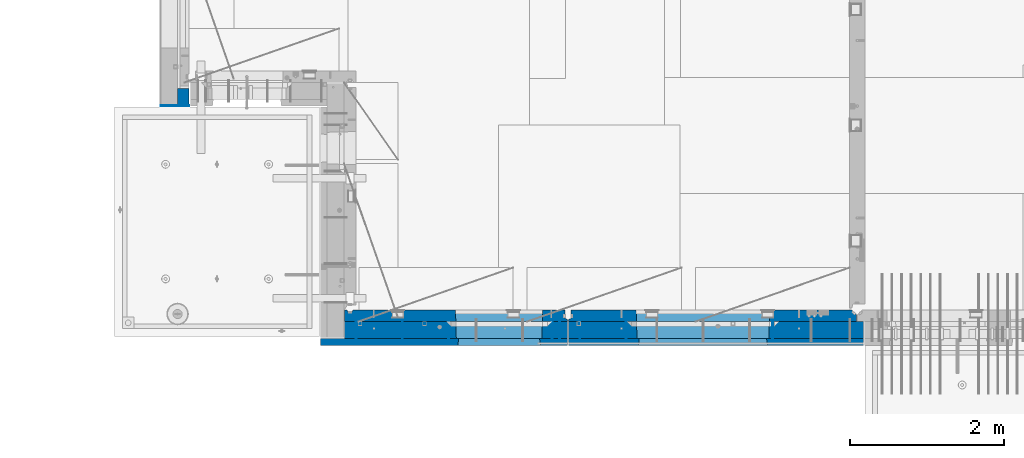
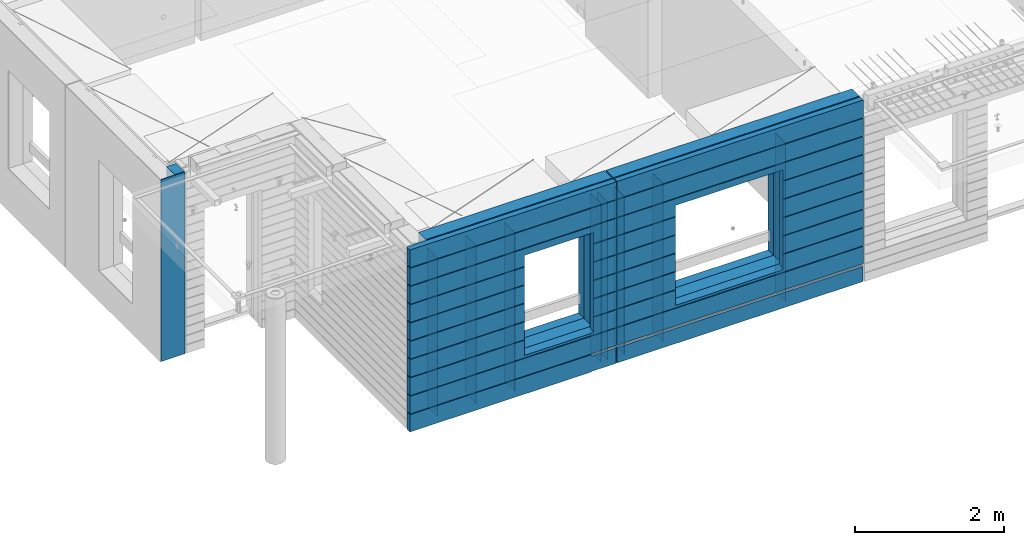
# One storey, part 227 of 350: 16 walls, 3 elements without a shape of their own.
"""IFC2X3 building model written with IfcOpenShell, lengths in millimetres."""

from ifc_helpers import new_model, si_unit, frame, origin_with_axes, place, context, subcontext, project, spatial, faceted_brep, material, type_object, element, aggregate, save


model = new_model("IFC2X3")

# Units and contexts
model_context = context("Model", 3, precision=1e-05, world=origin_with_axes())
body_context = subcontext(model_context, "Body", "Model", "MODEL_VIEW")
ifc_project = project(units=[si_unit("LENGTHUNIT", "METRE", prefix="MILLI"), si_unit("AREAUNIT", "SQUARE_METRE"), si_unit("VOLUMEUNIT", "CUBIC_METRE"), si_unit("MASSUNIT", "GRAM", prefix="KILO"), si_unit("TIMEUNIT", "SECOND"), si_unit("PLANEANGLEUNIT", "RADIAN"), si_unit("SOLIDANGLEUNIT", "STERADIAN"), si_unit("THERMODYNAMICTEMPERATUREUNIT", "DEGREE_CELSIUS"), si_unit("LUMINOUSINTENSITYUNIT", "LUMEN")], contexts=[model_context])

# Site, building, storey
site_placement = place(None, origin_with_axes())
site = spatial("IfcSite", under=ifc_project, at=site_placement, CompositionType="ELEMENT")
building_placement = place(site_placement, origin_with_axes())
building = spatial("IfcBuilding", under=site, at=building_placement, CompositionType="ELEMENT")
storey_placement = place(building_placement, origin_with_axes())
storey = spatial("IfcBuildingStorey", under=building, at=storey_placement, Name="2", CompositionType="ELEMENT", Elevation=0.0)

# Assembly, walls
assembly_1_placement = place(storey_placement, origin_with_axes())
assembly_1 = element("IfcElementAssembly", 1, at=assembly_1_placement, inside=storey, AssemblyPlace="NOTDEFINED", PredefinedType="REINFORCEMENT_UNIT")
ifc_material_1 = material(Name="Undefined")
wall_type_1 = type_object("IfcWallType", PredefinedType="NOTDEFINED")
wall_1_placement = place(assembly_1_placement, frame((10165.0, 7880.0, 86115.0), z_axis=(0.0, 0.0, 1.0), x_axis=(0.0, -1.0, 0.0)))
wall_1 = element("IfcWall", 2, at=wall_1_placement, type_object=wall_type_1, material=ifc_material_1, Name="(PD)", context=body_context, shape_type="Brep", body=[
    faceted_brep([(0.0, 5.0, -1300.0), (0.0, 5.0, 1300.0), (280.0, 5.0, 1300.0), (280.0, 5.0, -1300.0), (0.0, -5.0, 1300.0), (280.0, -5.0, 1300.0), (0.0, -5.0, -1300.0), (280.0, -5.0, -1300.0)], [[[0, 1, 2, 3]], [[1, 4, 5, 2]], [[4, 6, 7, 5]], [[6, 0, 3, 7]], [[5, 7, 3, 2]], [[6, 4, 1, 0]]]),
])
wall_2_placement = place(assembly_1_placement, frame((10765.0, 7880.0, 86115.0), z_axis=(0.0, 0.0, 1.0), x_axis=(0.0, -1.0, 0.0)))
wall_2 = element("IfcWall", 3, at=wall_2_placement, type_object=wall_type_1, material=ifc_material_1, Name="(PD)", context=body_context, shape_type="Brep", body=[
    faceted_brep([(0.0, 5.0, -1300.0), (0.0, 5.0, 1300.0), (280.0, 5.0, 1300.0), (280.0, 5.0, -1300.0), (0.0, -5.0, 1300.0), (280.0, -5.0, 1300.0), (0.0, -5.0, -1300.0), (280.0, -5.0, -1300.0)], [[[0, 1, 2, 3]], [[1, 4, 5, 2]], [[4, 6, 7, 5]], [[6, 0, 3, 7]], [[5, 7, 3, 2]], [[6, 4, 1, 0]]]),
])
wall_3_placement = place(assembly_1_placement, frame((12705.0, 7880.0, 86115.0), z_axis=(0.0, 0.0, 1.0), x_axis=(0.0, -1.0, 0.0)))
wall_3 = element("IfcWall", 4, at=wall_3_placement, type_object=wall_type_1, material=ifc_material_1, Name="(PD)", context=body_context, shape_type="Brep", body=[
    faceted_brep([(0.0, 5.0, -1300.0), (0.0, 5.0, 1300.0), (280.0, 5.0, 1300.0), (280.0, 5.0, -1300.0), (0.0, -5.0, 1300.0), (280.0, -5.0, 1300.0), (0.0, -5.0, -1300.0), (280.0, -5.0, -1300.0)], [[[0, 1, 2, 3]], [[1, 4, 5, 2]], [[4, 6, 7, 5]], [[6, 0, 3, 7]], [[5, 7, 3, 2]], [[6, 4, 1, 0]]]),
])
wall_4_placement = place(assembly_1_placement, frame((12805.0, 7880.0, 86115.0), z_axis=(0.0, 0.0, 1.0), x_axis=(0.0, -1.0, 0.0)))
wall_4 = element("IfcWall", 5, at=wall_4_placement, type_object=wall_type_1, material=ifc_material_1, Name="(PD)", context=body_context, shape_type="Brep", body=[
    faceted_brep([(0.0, 5.0, -1300.0), (0.0, 5.0, 1300.0), (280.0, 5.0, 1300.0), (280.0, 5.0, -1300.0), (0.0, -5.0, 1300.0), (280.0, -5.0, 1300.0), (0.0, -5.0, -1300.0), (280.0, -5.0, -1300.0)], [[[0, 1, 2, 3]], [[1, 4, 5, 2]], [[4, 6, 7, 5]], [[6, 0, 3, 7]], [[5, 7, 3, 2]], [[6, 4, 1, 0]]]),
])
wall_5_placement = place(assembly_1_placement, frame((11365.0, 7880.0, 86115.0), z_axis=(0.0, 0.0, 1.0), x_axis=(0.0, -1.0, 0.0)))
wall_5 = element("IfcWall", 6, at=wall_5_placement, type_object=wall_type_1, material=ifc_material_1, Name="(PD)", context=body_context, shape_type="Brep", body=[
    faceted_brep([(0.0, 5.0, -1300.0), (0.0, 5.0, 1300.0), (280.0, 5.0, 1300.0), (280.0, 5.0, -1300.0), (0.0, -5.0, 1300.0), (280.0, -5.0, 1300.0), (0.0, -5.0, -1300.0), (280.0, -5.0, -1300.0)], [[[0, 1, 2, 3]], [[1, 4, 5, 2]], [[4, 6, 7, 5]], [[6, 0, 3, 7]], [[5, 7, 3, 2]], [[6, 4, 1, 0]]]),
])

assembly_2_placement = place(storey_placement, origin_with_axes())
assembly_2 = element("IfcElementAssembly", 7, at=assembly_2_placement, inside=storey, AssemblyPlace="NOTDEFINED", PredefinedType="REINFORCEMENT_UNIT")
wall_6_placement = place(assembly_2_placement, frame((13665.0, 7880.0, 86115.0), z_axis=(0.0, 0.0, 1.0), x_axis=(0.0, -1.0, 0.0)))
wall_6 = element("IfcWall", 8, at=wall_6_placement, type_object=wall_type_1, material=ifc_material_1, Name="(PD)", context=body_context, shape_type="Brep", body=[
    faceted_brep([(0.0, 5.0, -1300.0), (0.0, 5.0, 1300.0), (280.0, 5.0, 1300.0), (280.0, 5.0, -1300.0), (0.0, -5.0, 1300.0), (280.0, -5.0, 1300.0), (0.0, -5.0, -1300.0), (280.0, -5.0, -1300.0)], [[[0, 1, 2, 3]], [[1, 4, 5, 2]], [[4, 6, 7, 5]], [[6, 0, 3, 7]], [[5, 7, 3, 2]], [[6, 4, 1, 0]]]),
])
wall_7_placement = place(assembly_2_placement, frame((13065.0, 7880.0, 86115.0), z_axis=(0.0, 0.0, 1.0), x_axis=(0.0, -1.0, 0.0)))
wall_7 = element("IfcWall", 9, at=wall_7_placement, type_object=wall_type_1, material=ifc_material_1, Name="(PD)", context=body_context, shape_type="Brep", body=[
    faceted_brep([(0.0, 5.0, -1300.0), (0.0, 5.0, 1300.0), (280.0, 5.0, 1300.0), (280.0, 5.0, -1300.0), (0.0, -5.0, 1300.0), (280.0, -5.0, 1300.0), (0.0, -5.0, -1300.0), (280.0, -5.0, -1300.0)], [[[0, 1, 2, 3]], [[1, 4, 5, 2]], [[4, 6, 7, 5]], [[6, 0, 3, 7]], [[5, 7, 3, 2]], [[6, 4, 1, 0]]]),
])
wall_8_placement = place(assembly_2_placement, frame((15565.0, 7880.0, 86115.0), z_axis=(0.0, 0.0, 1.0), x_axis=(0.0, -1.0, 0.0)))
wall_8 = element("IfcWall", 10, at=wall_8_placement, type_object=wall_type_1, material=ifc_material_1, Name="(PD)", context=body_context, shape_type="Brep", body=[
    faceted_brep([(0.0, 5.0, -1300.0), (0.0, 5.0, 1300.0), (280.0, 5.0, 1300.0), (280.0, 5.0, -1300.0), (0.0, -5.0, 1300.0), (280.0, -5.0, 1300.0), (0.0, -5.0, -1300.0), (280.0, -5.0, -1300.0)], [[[0, 1, 2, 3]], [[1, 4, 5, 2]], [[4, 6, 7, 5]], [[6, 0, 3, 7]], [[5, 7, 3, 2]], [[6, 4, 1, 0]]]),
])

# Assembly, wall
assembly_3_placement = place(storey_placement, origin_with_axes())
assembly_3 = element("IfcElementAssembly", 11, at=assembly_3_placement, inside=storey, AssemblyPlace="NOTDEFINED", PredefinedType="REINFORCEMENT_UNIT")
ifc_material_2 = material()
wall_type_2 = type_object("IfcWallType", PredefinedType="NOTDEFINED")
wall_9_placement = place(assembly_3_placement, frame((8000.00051558999, 10765.0000158944, 86247.5), z_axis=(0.0, 0.0, 1.0), x_axis=(-0.999999999997437, -2.26400000064461e-06, 0.0)))
wall_9 = element("IfcWall", 12, at=wall_9_placement, type_object=wall_type_2, material=ifc_material_2, context=body_context, shape_type="Brep", body=[
    faceted_brep([(0.0, 110.0, -1492.5), (0.0, 110.0, 1492.5), (150.000694320282, 109.999999999998, 1492.5), (150.000694320282, 109.999999999998, -1492.5), (0.0, -110.0, 1492.5), (150.000694320282, -110.000000000004, 1492.5), (0.0, -110.0, -1492.5), (150.000694320282, -110.000000000004, -1492.5)], [[[0, 1, 2, 3]], [[1, 4, 5, 2]], [[4, 6, 7, 5]], [[6, 0, 3, 7]], [[5, 7, 3, 2]], [[6, 4, 1, 0]]]),
])

# Wall
ifc_material_3 = material(Name="COS5gt")
wall_10_placement = place(assembly_1_placement, frame((12912.5, 7740.0, 86247.5), z_axis=(0.0, 0.0, 1.0), x_axis=(-1.0, 3.00000001838171e-08, 0.0)))
wall_10 = element("IfcWall", 13, at=wall_10_placement, type_object=wall_type_2, material=ifc_material_3, context=body_context, shape_type="Brep", body=[
    faceted_brep([(7.5, 90.0, 1442.5), (2897.5, 90.0, 1442.5), (2897.5, 110.0, 1442.5), (7.5, 110.0, 1442.5), (7.5, 90.0, 1492.5), (2897.5, 90.0, 1492.5), (7.5, -110.0, 1492.5), (2897.5, -110.0, 1492.5), (2897.5, -110.0, -1492.5), (2897.5, 90.0, -1492.5), (2897.5, 90.0, -1442.5), (2897.5, 110.0, -1442.5), (7.5, 110.0, -1442.5), (7.5, 90.0, -1442.5), (339.499571152144, 110.0, -807.5), (369.499571152144, 110.0, -807.5), (1419.49957115214, 110.0, -807.5), (1449.49957115214, 110.0, -807.5), (1449.49957115214, 110.0, -802.5), (1449.49957115214, 110.0, 807.5), (339.499571152144, 110.0, 807.5), (339.499571152144, 110.0, -802.5), (333.553625206197, -110.0, -813.445945945947), (333.553625206197, -110.0, 813.445945945947), (1455.44551709809, -110.0, -813.445945945947), (1455.44551709809, -110.0, 813.445945945947), (7.5, -110.0, -1492.5), (7.5, 90.0, -1492.5)], [[[0, 1, 2, 3]], [[4, 5, 1, 0]], [[6, 7, 5, 4]], [[2, 1, 5, 7, 8, 9, 10, 11]], [[12, 11, 10, 13]], [[3, 2, 11, 12], [14, 15, 16, 17, 18, 19, 20, 21]], [[22, 14, 21, 20, 23]], [[24, 17, 16, 15, 14, 22]], [[18, 17, 24, 25, 19]], [[23, 20, 19, 25]], [[6, 26, 8, 7], [24, 22, 23, 25]], [[8, 26, 27, 9]], [[13, 10, 9, 27]], [[26, 6, 4, 0, 3, 12, 13, 27]]]),
])

wall_11_placement = place(assembly_2_placement, frame((16740.0, 7740.0, 86247.5), z_axis=(0.0, 0.0, 1.0), x_axis=(-1.0, 3.00000001838171e-08, 0.0)))
wall_11 = element("IfcWall", 14, at=wall_11_placement, type_object=wall_type_2, material=ifc_material_3, context=body_context, shape_type="Brep", body=[
    faceted_brep([(0.0, 90.0, 1442.5), (3820.0, 90.0, 1442.5), (3820.0, 110.0, 1442.5), (0.0, 110.0, 1442.5), (0.0, 90.0, 1492.5), (3820.0, 90.0, 1492.5), (0.0, -110.0, 1492.5), (3820.0, -110.0, 1492.5), (3820.0, -110.0, -1492.5), (3820.0, 90.0, -1492.5), (3820.0, 90.0, -1442.5), (3820.0, 110.0, -1442.5), (0.0, 110.0, -1442.5), (0.0, 90.0, -1442.5), (1224.99975425761, 110.0, -807.5), (1254.99975425761, 110.0, -807.5), (2904.99975425761, 110.0, -807.5), (2934.99975425761, 110.0, -807.5), (2934.99975425761, 110.0, -802.5), (2934.99975425761, 110.0, 807.5), (1224.99975425761, 110.0, 807.5), (1224.99975425761, 110.0, -802.5), (1219.05380831167, -110.0, -813.445945945947), (1219.05380831167, -110.0, 813.445945945947), (2940.94570020356, -110.0, -813.445945945947), (2940.94570020356, -110.0, 813.445945945947), (0.0, -110.0, -1492.5), (0.0, 90.0, -1492.5)], [[[0, 1, 2, 3]], [[4, 5, 1, 0]], [[6, 7, 5, 4]], [[2, 1, 5, 7, 8, 9, 10, 11]], [[12, 11, 10, 13]], [[3, 2, 11, 12], [14, 15, 16, 17, 18, 19, 20, 21]], [[22, 14, 21, 20, 23]], [[24, 17, 16, 15, 14, 22]], [[18, 17, 24, 25, 19]], [[23, 20, 19, 25]], [[6, 26, 8, 7], [24, 22, 23, 25]], [[8, 26, 27, 9]], [[13, 10, 9, 27]], [[27, 26, 6, 4, 0, 3, 12, 13]]]),
])

ifc_material_4 = material(Name="CONCRETE/C30/37")
wall_type_3 = type_object("IfcWallType", PredefinedType="NOTDEFINED")
wall_12_placement = place(assembly_1_placement, frame((12912.5, 7587.5, 86247.5), z_axis=(0.0, 0.0, 1.0), x_axis=(-1.0, 3.00000001838171e-08, 0.0)))
wall_12 = element("IfcWall", 15, at=wall_12_placement, type_object=wall_type_3, material=ifc_material_4, context=body_context, shape_type="Brep", body=[
    faceted_brep([(3207.5, -42.5, 1193.0000011433), (3207.5, 42.5, 1192.99999994476), (3197.49999925687, 32.4999992501671, 1194.99999999921), (3197.49999396174, -42.5, 1195.00000105656), (3197.49999368253, -42.5, 1205.00000145777), (3197.49999897767, 32.4999991121604, 1205.00000040043), (3207.5, 42.5, 1206.99999988925), (3207.5, -42.5, 1207.0000010878), (392.5, 32.4999992501653, -1205.00000000079), (392.5, 32.4999991121585, -1194.99999959957), (3197.49999897767, 32.4999991121604, -1194.99999959957), (3197.49999925687, 32.4999992501671, -1205.00000000079), (392.5, 42.5, -1207.00000005524), (3207.5, 42.5, -1207.00000005524), (3207.5, 42.5, -1492.5), (392.5, 42.5, -1492.5), (392.5, 32.4999991121731, -1492.49999959956), (392.5, 32.4999992319263, -1243.00000011073), (392.5, 7.5, -1243.00000011073), (392.5, 7.5, -1193.00000011073), (392.5, 32.5, -1193.00000011073), (7.5, 32.5, -1193.00000011073), (7.5, 7.5, -1193.00000011073), (7.4999999999709, 32.4999991121604, -1194.99999959957), (7.4999999999709, 42.5, -1193.00000011075), (3207.5, 42.5, -1193.00000011075), (7.4999999999709, 42.5, -907.000000055239), (3207.5, 42.5, -907.000000055239), (7.4999999999709, 32.4999992501671, -905.000000000786), (3197.49999925687, 32.4999992501671, -905.000000000786), (7.4999999999709, 32.4999991121604, -894.999999599575), (3197.49999897767, 32.4999991121604, -894.999999599575), (7.4999999999709, 42.5, -893.000000110755), (3207.5, 42.5, -893.000000110755), (1429.49957115214, 42.5, -607.000000055239), (1428.32310047569, 32.4999992501653, -605.000000000786), (3197.49999925687, 32.4999992501671, -605.000000000786), (3207.5, 42.5, -607.000000055239), (1428.32310045946, 32.4999991121585, -594.999999599575), (3197.49999897767, 32.4999991121604, -594.999999599575), (1429.49957115214, 42.5, -593.000000110755), (3207.5, 42.5, -593.000000110755), (3207.5, 42.5, -307.000000055239), (1429.49957115214, 42.5, -307.000000055239), (1428.32310047569, 32.4999992501653, -305.000000000786), (3197.49999925687, 32.4999992501671, -305.000000000786), (1428.32310045946, 32.4999991121585, -294.999999599575), (3197.49999897767, 32.4999991121604, -294.999999599575), (1429.49957115214, 42.5, -293.000000110755), (3207.5, 42.5, -293.000000110755), (3207.5, 42.5, -7.00000005523907), (1429.49957115214, 42.5, -7.00000005523907), (1428.32310047569, 32.4999992501653, -5.0000000007858), (3197.49999925687, 32.4999992501671, -5.0000000007858), (1428.32310045946, 32.4999991121585, 5.00000040042505), (3197.49999897767, 32.4999991121604, 5.00000040042505), (1429.49957115214, 42.5, 6.99999988924537), (3207.5, 42.5, 6.99999988924537), (3207.5, 42.5, 292.999999944761), (1429.49957115214, 42.5, 292.999999944761), (1428.32310047569, 32.4999992501653, 294.999999999214), (3197.49999925687, 32.4999992501671, 294.999999999214), (1428.32310045946, 32.4999991121585, 305.000000400425), (3197.49999897767, 32.4999991121604, 305.000000400425), (1429.49957115214, 42.5, 306.999999889245), (3207.5, 42.5, 306.999999889245), (3207.5, 42.5, 592.999999944761), (1429.49957115214, 42.5, 592.999999944761), (1428.32310047569, 32.4999992501653, 594.999999999214), (3197.49999925687, 32.4999992501671, 594.999999999214), (1428.32310045946, 32.4999991121585, 605.000000400425), (3197.49999897767, 32.4999991121604, 605.000000400425), (1429.49957115214, 42.5, 606.999999889245), (3207.5, 42.5, 606.999999889245), (7.4999999999709, 42.5, 892.999999944761), (7.49999999998181, 32.4999992501671, 894.999999999214), (3197.49999925687, 32.4999992501671, 894.999999999214), (3207.5, 42.5, 892.999999944761), (7.49999999998181, 32.4999991121604, 905.000000400425), (3197.49999897767, 32.4999991121604, 905.000000400425), (7.4999999999709, 42.5, 906.999999889245), (3207.5, 42.5, 906.999999889245), (7.4999999999709, 42.5, 1492.5), (7.4999999999709, -42.5, 1492.5), (3207.5, -42.5, 1492.5), (3207.5, 42.5, 1492.5), (7.4999999999709, 42.5, 1206.99999988925), (7.49999999998363, 32.4999991121604, 1205.00000040043), (7.49999999998363, 32.4999992501671, 1194.99999999921), (7.4999999999709, 42.5, 1192.99999994476), (3207.5, -42.5, 907.000001087799), (3197.49999368253, -42.5, 905.000001457767), (3197.49999396174, -42.5, 895.000001056556), (3207.5, -42.5, 893.0000011433), (3207.5, -42.5, 607.000001087799), (3197.49999368253, -42.5, 605.000001457767), (3197.49999396174, -42.5, 595.000001056556), (3207.5, -42.5, 593.0000011433), (3207.5, -42.5, 307.000001087799), (3197.49999368253, -42.5, 305.000001457767), (3197.49999396174, -42.5, 295.000001056556), (3207.5, -42.5, 293.0000011433), (3207.5, -42.5, 7.00000108779932), (3197.49999368253, -42.5, 5.00000145776721), (3197.49999396174, -42.5, -4.99999894344364), (3207.5, -42.5, -6.99999885669968), (3207.5, -42.5, -292.999998912201), (3197.49999368253, -42.5, -294.999998542233), (3197.49999396174, -42.5, -304.999998943444), (3207.5, -42.5, -306.9999988567), (3207.5, -42.5, -592.999998912201), (3197.49999368253, -42.5, -594.999998542233), (3197.49999396174, -42.5, -604.999998943444), (3207.5, -42.5, -606.9999988567), (3207.5, -42.5, -892.999998912201), (3197.49999368253, -42.5, -894.999998542233), (3197.49999396174, -42.5, -904.999998943444), (3207.5, -42.5, -906.9999988567), (3207.5, -42.5, -1192.9999989122), (3197.49999368253, -42.5, -1194.99999854223), (3197.49999396174, -42.5, -1204.99999894344), (3207.5, -42.5, -1206.9999988567), (3207.5, -42.5, -1492.5), (7.4999999999709, -42.5, -1492.5), (7.4999999999709, 32.4999991121731, -1492.5), (7.49999999999636, 32.4999991121731, -1243.00000011073), (7.5, 7.5, -1243.00000011073), (7.4999999999709, 42.5, 606.999999889245), (7.49999999997999, 32.4999991121604, 605.000000400425), (7.49999999997999, 32.4999992501671, 594.999999999214), (7.4999999999709, 42.5, 592.999999944761), (7.4999999999709, 42.5, 306.999999889245), (7.49999999997453, 32.4999991121604, 305.000000400425), (7.49999999997453, 32.4999992501671, 294.999999999214), (7.4999999999709, 42.5, 292.999999944761), (7.4999999999709, 42.5, 6.99999988924537), (7.4999999999709, 32.4999991121604, 5.00000040042505), (7.4999999999709, 32.4999992501671, -5.0000000007858), (7.4999999999709, 42.5, -7.00000005523907), (7.4999999999709, 42.5, -293.000000110755), (7.4999999999709, 32.4999991121604, -294.999999599575), (7.4999999999709, 32.4999992501671, -305.000000000786), (7.4999999999709, 42.5, -307.000000055239), (7.4999999999709, 42.5, -593.000000110755), (7.49999999996908, 32.4999991121604, -594.999999599575), (7.49999999996908, 32.4999992501671, -605.000000000786), (7.4999999999709, 42.5, -607.000000055239), (360.676041844832, 32.4999991121585, 605.000000400425), (360.676041828596, 32.4999992501653, 594.999999999214), (359.499571152144, 42.5, 592.999999944761), (359.499571152144, 42.5, 306.999999889245), (360.676041844832, 32.4999991121585, 305.000000400425), (360.676041828596, 32.4999992501653, 294.999999999214), (359.499571152144, 42.5, 292.999999944761), (359.499571152144, 42.5, 6.99999988924537), (360.676041844832, 32.4999991121585, 5.00000040042505), (360.676041828596, 32.4999992501653, -5.0000000007858), (359.499571152144, 42.5, -7.00000005523907), (359.499571152144, 42.5, -293.000000110755), (360.676041844832, 32.4999991121585, -294.999999599575), (360.676041828596, 32.4999992501653, -305.000000000786), (359.499571152144, 42.5, -307.000000055239), (359.499571152144, 42.5, -593.000000110755), (360.676041844832, 32.4999991121585, -594.999999599575), (360.676041828596, 32.4999992501653, -605.000000000786), (359.499571152144, 42.5, -607.000000055239), (1429.49957115214, 42.5, -857.5), (359.499571152144, 42.5, -857.5), (369.499571152144, -42.5, -807.5), (1419.49957115214, -42.5, -807.5), (1419.49957115214, -42.5, 782.5), (1419.49957115214, -42.5, 787.5), (1429.49957115214, 42.5, 782.5), (1419.49957115214, 42.5, 782.5), (369.499571152144, 42.5, 782.5), (359.499571152144, 42.5, 782.5), (359.499571152144, 42.5, 606.999999889245), (369.499571152144, -42.5, 787.5), (369.499571152144, -42.5, 782.5)], [[[0, 1, 2, 3]], [[4, 5, 6, 7]], [[3, 2, 5, 4]], [[8, 9, 10, 11]], [[12, 8, 11, 13]], [[13, 14, 15, 12]], [[12, 15, 16, 17, 8]], [[8, 17, 18, 19, 20, 9]], [[21, 20, 19, 22]], [[23, 9, 20, 21]], [[9, 23, 24, 25, 10]], [[25, 24, 26, 27]], [[26, 28, 29, 27]], [[28, 30, 31, 29]], [[30, 32, 33, 31]], [[34, 35, 36, 37]], [[35, 38, 39, 36]], [[38, 40, 41, 39]], [[42, 41, 40, 43]], [[43, 44, 45, 42]], [[44, 46, 47, 45]], [[46, 48, 49, 47]], [[50, 49, 48, 51]], [[51, 52, 53, 50]], [[52, 54, 55, 53]], [[54, 56, 57, 55]], [[58, 57, 56, 59]], [[59, 60, 61, 58]], [[60, 62, 63, 61]], [[62, 64, 65, 63]], [[66, 65, 64, 67]], [[67, 68, 69, 66]], [[68, 70, 71, 69]], [[70, 72, 73, 71]], [[74, 75, 76, 77]], [[75, 78, 79, 76]], [[78, 80, 81, 79]], [[82, 83, 84, 85]], [[85, 84, 7, 6]], [[82, 85, 6, 86]], [[87, 86, 6, 5]], [[88, 87, 5, 2]], [[89, 88, 2, 1]], [[81, 80, 89, 1]], [[90, 81, 1, 0]], [[91, 79, 81, 90]], [[92, 76, 79, 91]], [[93, 77, 76, 92]], [[94, 73, 77, 93]], [[95, 71, 73, 94]], [[96, 69, 71, 95]], [[97, 66, 69, 96]], [[98, 65, 66, 97]], [[99, 63, 65, 98]], [[100, 61, 63, 99]], [[101, 58, 61, 100]], [[102, 57, 58, 101]], [[103, 55, 57, 102]], [[104, 53, 55, 103]], [[105, 50, 53, 104]], [[106, 49, 50, 105]], [[107, 47, 49, 106]], [[108, 45, 47, 107]], [[109, 42, 45, 108]], [[110, 41, 42, 109]], [[111, 39, 41, 110]], [[112, 36, 39, 111]], [[113, 37, 36, 112]], [[114, 33, 37, 113]], [[115, 31, 33, 114]], [[116, 29, 31, 115]], [[117, 27, 29, 116]], [[118, 25, 27, 117]], [[119, 10, 25, 118]], [[120, 11, 10, 119]], [[121, 13, 11, 120]], [[122, 14, 13, 121]], [[15, 14, 122, 123, 124, 16]], [[16, 124, 125, 17]], [[126, 18, 17, 125]], [[22, 19, 18, 126]], [[125, 124, 123, 83, 82, 86, 87, 88, 89, 80, 78, 75, 74, 127, 128, 129, 130, 131, 132, 133, 134, 135, 136, 137, 138, 139, 140, 141, 142, 143, 144, 145, 146, 32, 30, 28, 26, 24, 23, 21, 22, 126]], [[129, 128, 147, 148]], [[130, 129, 148, 149]], [[131, 130, 149, 150]], [[132, 131, 150, 151]], [[133, 132, 151, 152]], [[134, 133, 152, 153]], [[135, 134, 153, 154]], [[136, 135, 154, 155]], [[137, 136, 155, 156]], [[138, 137, 156, 157]], [[139, 138, 157, 158]], [[140, 139, 158, 159]], [[141, 140, 159, 160]], [[142, 141, 160, 161]], [[143, 142, 161, 162]], [[144, 143, 162, 163]], [[145, 144, 163, 164]], [[146, 145, 164, 165]], [[166, 34, 37, 33, 32, 146, 165, 167]], [[167, 168, 169, 166]], [[170, 171, 172, 72, 70, 68, 67, 64, 62, 60, 59, 56, 54, 52, 51, 48, 46, 44, 43, 40, 38, 35, 34, 166, 169]], [[127, 74, 77, 73, 72, 172, 173, 174, 175, 176]], [[128, 127, 176, 147]], [[175, 177, 178, 168, 167, 165, 164, 163, 162, 161, 160, 159, 158, 157, 156, 155, 154, 153, 152, 151, 150, 149, 148, 147, 176]], [[174, 173, 172, 171, 177, 175]], [[84, 83, 123, 122, 121, 120, 119, 118, 117, 116, 115, 114, 113, 112, 111, 110, 109, 108, 107, 106, 105, 104, 103, 102, 101, 100, 99, 98, 97, 96, 95, 94, 93, 92, 91, 90, 0, 3, 4, 7], [170, 169, 168, 178, 177, 171]]]),
])

wall_13_placement = place(assembly_2_placement, frame((16740.0, 7587.5, 86247.5), z_axis=(0.0, 0.0, 1.0), x_axis=(-1.0, 3.00000001838171e-08, 0.0)))
wall_13 = element("IfcWall", 16, at=wall_13_placement, type_object=wall_type_3, material=ifc_material_4, context=body_context, shape_type="Brep", body=[
    faceted_brep([(0.0, 7.5, -1243.00000011073), (3820.0, 7.5, -1243.00000011073), (3820.00000000003, 32.4999992319299, -1243.00000011073), (0.0, 32.4999992319299, -1243.00000011073), (0.0, 7.5, -1193.00000011073), (3820.0, 7.5, -1193.00000011073), (0.0, 32.4999994960417, -1192.99999940711), (3820.00000000003, 32.4999994960417, -1192.99999940711), (0.0, 42.5, 1492.5), (0.0, -42.5, 1492.5), (3820.00000000003, -42.5, 1492.5), (3820.00000000003, 42.5, 1492.5), (3820.00000000003, 42.5, 1206.99999988925), (0.0, 42.5, 1206.99999988925), (3820.00000000002, 32.4999991121731, 1205.00000040044), (0.0, 32.4999991127006, 1205.00000040044), (3820.00000000002, 32.4999992501716, 1194.99999999924), (0.0, 32.4999992507037, 1194.99999999926), (3820.00000000003, 42.5, 1192.99999994476), (0.0, 42.5, 1192.99999994476), (3820.00000000003, 42.5, 906.999999889245), (0.0, 42.5, 906.999999889245), (3820.00000000002, 32.4999991121731, 905.00000040044), (0.0, 32.4999991127006, 905.00000040044), (3820.00000000002, 32.4999992501716, 894.999999999243), (0.0, 32.4999992507037, 894.999999999258), (3820.00000000003, 42.5, 892.999999944761), (0.0, 42.5, 892.999999944761), (3820.00000000003, 42.5, 606.999999889245), (3820.00000000002, 32.4999991121731, 605.00000040044), (2913.82328356493, 32.4999991121731, 605.00000040044), (2914.99975425761, 42.5, 606.999999889245), (3820.00000000002, 32.4999992501716, 594.999999999243), (2913.82328358116, 32.4999992501716, 594.999999999243), (3820.00000000003, 42.5, 592.999999944761), (2914.99975425761, 42.5, 592.999999944761), (3820.00000000003, 42.5, 306.999999889245), (2914.99975425761, 42.5, 306.999999889245), (3820.00000000002, 32.4999991121731, 305.00000040044), (2913.82328356493, 32.4999991121731, 305.00000040044), (3820.00000000002, 32.4999992501716, 294.999999999243), (2913.82328358116, 32.4999992501716, 294.999999999243), (3820.00000000003, 42.5, 292.999999944761), (2914.99975425761, 42.5, 292.999999944761), (3820.00000000003, 42.5, 6.99999988924537), (2914.99975425761, 42.5, 6.99999988924537), (3820.00000000003, 32.4999991121731, 5.0000004004396), (2913.82328356493, 32.4999991121731, 5.0000004004396), (3820.00000000003, 32.4999992501716, -5.0000000007567), (2913.82328358116, 32.4999992501716, -5.0000000007567), (3820.00000000003, 42.5, -7.00000005523907), (2914.99975425761, 42.5, -7.00000005523907), (3820.00000000003, 42.5, -293.000000110755), (2914.99975425761, 42.5, -293.000000110755), (3820.00000000003, 32.4999991121731, -294.99999959956), (2913.82328356493, 32.4999991121731, -294.99999959956), (3820.00000000003, 32.4999992501716, -305.000000000757), (2913.82328358116, 32.4999992501716, -305.000000000757), (3820.00000000003, 42.5, -307.000000055239), (2914.99975425761, 42.5, -307.000000055239), (3820.00000000003, 42.5, -593.000000110755), (2914.99975425761, 42.5, -593.000000110755), (3820.00000000003, 32.4999991121731, -594.99999959956), (2913.82328356493, 32.4999991121731, -594.99999959956), (3820.00000000003, 32.4999992501716, -605.000000000757), (2913.82328358116, 32.4999992501716, -605.000000000757), (3820.00000000003, 42.5, -607.000000055239), (2914.99975425761, 42.5, -607.000000055239), (3820.00000000003, 42.5, -1193.00000011075), (0.0, 42.5, -1193.00000011075), (0.0, 42.5, -907.000000055239), (3820.00000000003, 42.5, -907.000000055239), (0.0, 32.4999992507037, -905.000000000742), (3820.00000000003, 32.4999992501716, -905.000000000757), (0.0, 32.4999991127006, -894.99999959956), (3820.00000000003, 32.4999991121731, -894.99999959956), (0.0, 42.5, -893.000000110755), (3820.00000000003, 42.5, -893.000000110755), (3.63797880709171e-12, 32.4999992507037, 594.999999999258), (3.63797880709171e-12, 32.4999991127006, 605.00000040044), (1246.1762249503, 32.4999991121731, 605.00000040044), (1246.17622493406, 32.4999992501716, 594.999999999243), (0.0, 42.5, 592.999999944761), (1244.99975425761, 42.5, 592.999999944761), (0.0, 42.5, 306.999999889245), (1244.99975425761, 42.5, 306.999999889245), (-3.63797880709171e-12, 32.4999991127006, 305.00000040044), (1246.1762249503, 32.4999991121731, 305.00000040044), (-3.63797880709171e-12, 32.4999992507037, 294.999999999258), (1246.17622493406, 32.4999992501716, 294.999999999243), (0.0, 42.5, 292.999999944761), (1244.99975425761, 42.5, 292.999999944761), (0.0, 42.5, 6.99999988924537), (1244.99975425761, 42.5, 6.99999988924537), (0.0, 32.4999991127006, 5.0000004004396), (1246.1762249503, 32.4999991121731, 5.0000004004396), (0.0, 32.4999992507037, -5.00000000074215), (1246.17622493406, 32.4999992501716, -5.0000000007567), (0.0, 42.5, -7.00000005523907), (1244.99975425761, 42.5, -7.00000005523907), (0.0, 42.5, -293.000000110755), (1244.99975425761, 42.5, -293.000000110755), (0.0, 32.4999991127006, -294.99999959956), (1246.1762249503, 32.4999991121731, -294.99999959956), (0.0, 32.4999992507037, -305.000000000742), (1246.17622493406, 32.4999992501716, -305.000000000757), (0.0, 42.5, -307.000000055239), (1244.99975425761, 42.5, -307.000000055239), (0.0, 42.5, -593.000000110755), (1244.99975425761, 42.5, -593.000000110755), (3.63797880709171e-12, 32.4999991127006, -594.99999959956), (1246.1762249503, 32.4999991121731, -594.99999959956), (3.63797880709171e-12, 32.4999992507037, -605.000000000742), (1246.17622493406, 32.4999992501716, -605.000000000757), (0.0, 42.5, -607.000000055239), (1244.99975425761, 42.5, -607.000000055239), (2914.99975425761, 42.5, -857.5), (1244.99975425761, 42.5, -857.5), (1254.99975425761, -42.5, -807.5), (2904.99975425761, -42.5, -807.5), (2904.99975425761, -42.5, 782.5), (2904.99975425761, -42.5, 787.5), (2914.99975425761, 42.5, 782.5), (0.0, 42.5, 606.999999889245), (2904.99975425761, 42.5, 782.5), (1254.99975425761, 42.5, 782.5), (1244.99975425761, 42.5, 782.5), (1244.99975425761, 42.5, 606.999999889245), (1254.99975425761, -42.5, 787.5), (1254.99975425761, -42.5, 782.5), (0.0, -42.5, -1492.5), (3820.00000000003, -42.5, -1492.5), (0.0, 32.4999991121731, -1492.5), (3820.00000000003, 32.4999991121731, -1492.5)], [[[0, 1, 2, 3]], [[4, 5, 1, 0]], [[6, 7, 5, 4]], [[8, 9, 10, 11]], [[8, 11, 12, 13]], [[13, 12, 14, 15]], [[15, 14, 16, 17]], [[17, 16, 18, 19]], [[20, 21, 19, 18]], [[21, 20, 22, 23]], [[23, 22, 24, 25]], [[25, 24, 26, 27]], [[28, 29, 30, 31]], [[29, 32, 33, 30]], [[32, 34, 35, 33]], [[34, 36, 37, 35]], [[36, 38, 39, 37]], [[38, 40, 41, 39]], [[40, 42, 43, 41]], [[42, 44, 45, 43]], [[44, 46, 47, 45]], [[46, 48, 49, 47]], [[48, 50, 51, 49]], [[50, 52, 53, 51]], [[52, 54, 55, 53]], [[54, 56, 57, 55]], [[56, 58, 59, 57]], [[58, 60, 61, 59]], [[60, 62, 63, 61]], [[62, 64, 65, 63]], [[64, 66, 67, 65]], [[68, 69, 70, 71]], [[72, 73, 71, 70]], [[74, 75, 73, 72]], [[76, 77, 75, 74]], [[78, 79, 80, 81]], [[82, 78, 81, 83]], [[84, 82, 83, 85]], [[86, 84, 85, 87]], [[88, 86, 87, 89]], [[90, 88, 89, 91]], [[92, 90, 91, 93]], [[94, 92, 93, 95]], [[96, 94, 95, 97]], [[98, 96, 97, 99]], [[100, 98, 99, 101]], [[102, 100, 101, 103]], [[104, 102, 103, 105]], [[106, 104, 105, 107]], [[108, 106, 107, 109]], [[110, 108, 109, 111]], [[112, 110, 111, 113]], [[114, 112, 113, 115]], [[116, 67, 66, 77, 76, 114, 115, 117]], [[117, 118, 119, 116]], [[120, 121, 122, 31, 30, 33, 35, 37, 39, 41, 43, 45, 47, 49, 51, 53, 55, 57, 59, 61, 63, 65, 67, 116, 119]], [[123, 27, 26, 28, 31, 122, 124, 125, 126, 127]], [[79, 123, 127, 80]], [[126, 128, 129, 118, 117, 115, 113, 111, 109, 107, 105, 103, 101, 99, 97, 95, 93, 91, 89, 87, 85, 83, 81, 80, 127]], [[125, 124, 122, 121, 128, 126]], [[9, 130, 131, 10], [120, 119, 118, 129, 128, 121]], [[131, 130, 132, 133]], [[133, 132, 3, 2]], [[68, 71, 73, 75, 77, 66, 64, 62, 60, 58, 56, 54, 52, 50, 48, 46, 44, 42, 40, 38, 36, 34, 32, 29, 28, 26, 24, 22, 20, 18, 16, 14, 12, 11, 10, 131, 133, 2, 1, 5, 7]], [[69, 68, 7, 6]], [[3, 132, 130, 9, 8, 13, 15, 17, 19, 21, 23, 25, 27, 123, 79, 78, 82, 84, 86, 88, 90, 92, 94, 96, 98, 100, 102, 104, 106, 108, 110, 112, 114, 76, 74, 72, 70, 69, 6, 4, 0]]]),
])

ifc_material_5 = material(Name="CONCRETE/C25/30")
wall_type_4 = type_object("IfcWallType", PredefinedType="NOTDEFINED")
wall_14_placement = place(assembly_1_placement, frame((12912.5, 7925.0, 86112.5), z_axis=(0.0, 0.0, 1.0), x_axis=(-1.0, 3.00000001838171e-08, 0.0)))
wall_14 = element("IfcWall", 17, at=wall_14_placement, type_object=wall_type_4, material=ifc_material_5, context=body_context, shape_type="Brep", body=[
    faceted_brep([(2787.5, -75.0, 1357.5), (2787.5, -75.0, -1357.5), (2800.5, -55.0, -1357.5), (2800.5, -55.0, 1357.5), (2852.5, -55.0, 1357.5), (2802.5, -55.0, 1357.5), (2802.5, -55.0, -1357.5), (2852.5, -55.0, -1357.5), (2854.5, -55.0, -1357.5), (2854.5, -55.0, 1357.5), (2867.5, -75.0, -1357.5), (2867.5, -75.0, 1357.5), (2897.5, -75.0, -1357.5), (2897.5, -75.0, 1357.5), (2897.5, 75.0, -1357.5), (2897.5, 75.0, 1357.5), (40.0, -75.0, 1357.5), (7.4999999999709, 75.0, 1357.5), (7.5, 45.0, 1357.5), (40.0, 32.0, 1357.5), (7.4999999999709, 75.0, -1357.5), (7.4999999999709, 45.0, -1357.5), (40.0, 32.0, -1357.5), (40.0, -75.0, -1357.5), (1459.49957115214, -75.0, -682.5), (329.499571152144, -75.0, -682.5), (329.499571152144, -75.0, 952.5), (1459.49957115214, -75.0, 952.5), (1455.44551709809, 75.0, -678.445945945947), (333.553625206197, 75.0, -678.445945945947), (333.553625206197, 75.0, 948.445945945947), (1455.44551709809, 75.0, 948.445945945947)], [[[0, 1, 2, 3]], [[4, 5, 3, 2, 6, 7, 8, 9]], [[9, 8, 10, 11]], [[12, 13, 11, 10]], [[13, 12, 14, 15]], [[16, 0, 3, 5, 4, 9, 11, 13, 15, 17, 18, 19]], [[17, 20, 21, 18]], [[18, 21, 22, 19]], [[20, 14, 12, 10, 8, 7, 6, 2, 1, 23, 22, 21]], [[16, 19, 22, 23]], [[1, 0, 16, 23], [24, 25, 26, 27]], [[24, 28, 29, 25]], [[25, 29, 30, 26]], [[20, 17, 15, 14], [28, 31, 30, 29]], [[26, 30, 31, 27]], [[28, 24, 27, 31]]]),
])

aggregate(assembly_1, [wall_1, wall_2, wall_3, wall_4, wall_5, wall_12, wall_10, wall_14])

wall_15_placement = place(assembly_2_placement, frame((16660.0, 7925.0, 86112.5), z_axis=(0.0, 0.0, 1.0), x_axis=(-1.0, 3.00000001838171e-08, 0.0)))
wall_15 = element("IfcWall", 18, at=wall_15_placement, type_object=wall_type_4, material=ifc_material_5, context=body_context, shape_type="Brep", body=[
    faceted_brep([(10.0, 75.0, 1357.5), (10.0, 75.0, -1357.5), (10.0, -15.0, -1357.5), (10.0, -15.0, 1357.5), (70.0, -75.0, -1357.5), (3740.00000000003, 75.0, -1357.5), (3740.00000000003, 45.0, -1357.5), (3707.5, 32.0, -1357.5), (3707.5, -75.0, -1357.5), (70.0, -75.0, 1357.5), (3740.00000000003, 45.0, 1357.5), (3740.00000000003, 75.0, 1357.5), (3707.5, -75.0, 1357.5), (3707.5, 32.0, 1357.5), (2864.99975425761, -75.0, -682.5), (1134.99975425761, -75.0, -682.5), (1134.99975425761, -75.0, 952.5), (2864.99975425761, -75.0, 952.5), (2860.94570020356, 75.0, -678.445945945947), (1139.05380831167, 75.0, -678.445945945947), (1139.05380831167, 75.0, 948.445945945947), (2860.94570020356, 75.0, 948.445945945947)], [[[0, 1, 2, 3]], [[4, 2, 1, 5, 6, 7, 8]], [[3, 2, 4, 9]], [[10, 11, 0, 3, 9, 12, 13]], [[5, 11, 10, 6]], [[13, 7, 6, 10]], [[12, 8, 7, 13]], [[9, 4, 8, 12], [14, 15, 16, 17]], [[14, 18, 19, 15]], [[15, 19, 20, 16]], [[1, 0, 11, 5], [18, 21, 20, 19]], [[16, 20, 21, 17]], [[18, 14, 17, 21]]]),
])

aggregate(assembly_2, [wall_6, wall_7, wall_8, wall_13, wall_11, wall_15])

wall_type_5 = type_object("IfcWallType", PredefinedType="NOTDEFINED")
wall_16_placement = place(assembly_3_placement, frame((8000.00033490857, 10650.0000304601, 86247.5), z_axis=(0.0, 0.0, 1.0), x_axis=(-1.0, 3.00000001838171e-08, 0.0)))
wall_16 = element("IfcWall", 19, at=wall_16_placement, type_object=wall_type_5, material=ifc_material_4, context=body_context, shape_type="Brep", body=[
    faceted_brep([(0.0, 5.0, -1492.5), (0.0, 5.0, 1492.5), (370.000694320092, 4.99999999999818, 1492.5), (370.000694320092, 4.99999999999818, -1492.5), (0.0, -5.0, 1492.5), (370.000694320092, -5.0, 1492.5), (0.0, -5.0, -1492.5), (370.000694320092, -5.0, -1492.5)], [[[0, 1, 2, 3]], [[1, 4, 5, 2]], [[4, 6, 7, 5]], [[6, 0, 3, 7]], [[5, 7, 3, 2]], [[6, 4, 1, 0]]]),
])

aggregate(assembly_3, [wall_16, wall_9])

save(model, "model.ifc")
